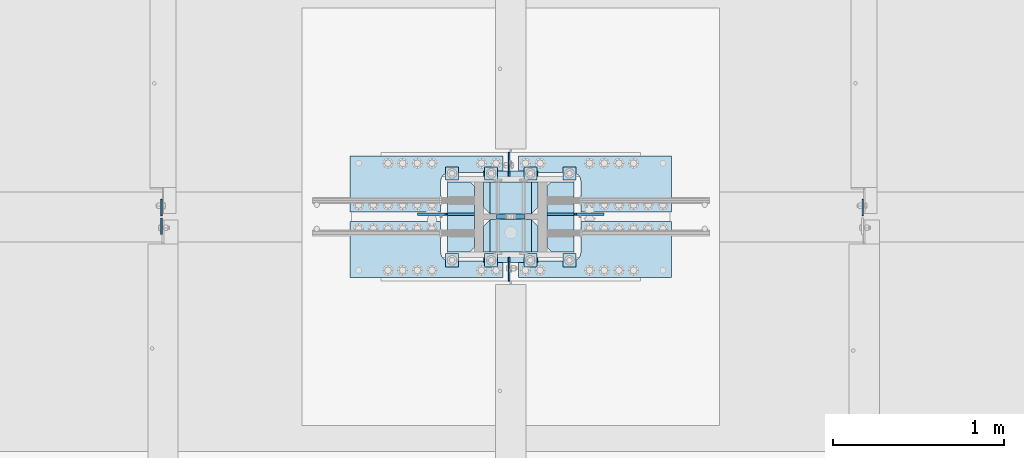
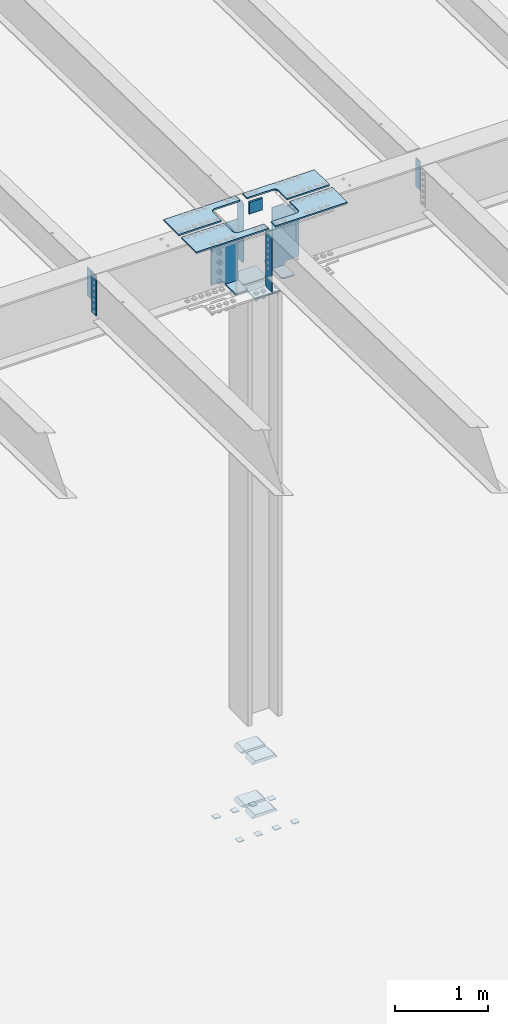
# One storey, part 1490 of 1763: 28 plates, 8 elements without a shape of their own.
"""IFC2X3 building model written with IfcOpenShell, lengths in millimetres."""

from ifc_helpers import new_model, si_unit, frame, origin_with_axes, place, context, subcontext, project, spatial, faceted_brep, material, type_object, element, aggregate, save


model = new_model("IFC2X3")

# Units and contexts
model_context = context("Model", 3, precision=1e-05, world=origin_with_axes())
body_context = subcontext(model_context, "Body", "Model", "MODEL_VIEW")
ifc_project = project(units=[si_unit("LENGTHUNIT", "METRE", prefix="MILLI"), si_unit("AREAUNIT", "SQUARE_METRE"), si_unit("VOLUMEUNIT", "CUBIC_METRE"), si_unit("MASSUNIT", "GRAM", prefix="KILO"), si_unit("TIMEUNIT", "SECOND"), si_unit("PLANEANGLEUNIT", "RADIAN"), si_unit("SOLIDANGLEUNIT", "STERADIAN"), si_unit("THERMODYNAMICTEMPERATUREUNIT", "DEGREE_CELSIUS"), si_unit("LUMINOUSINTENSITYUNIT", "LUMEN")], contexts=[model_context])

# Site, building, storey
site_placement = place(None, origin_with_axes())
site = spatial("IfcSite", under=ifc_project, at=site_placement, CompositionType="ELEMENT")
building_placement = place(site_placement, origin_with_axes())
building = spatial("IfcBuilding", under=site, at=building_placement, Name="Undefined", CompositionType="ELEMENT")
storey_placement = place(building_placement, origin_with_axes())
storey = spatial("IfcBuildingStorey", under=building, at=storey_placement, Name="Undefined", CompositionType="ELEMENT", Elevation=0.0)

# Assembly, plates
assembly_1_placement = place(storey_placement, origin_with_axes())
assembly_1 = element("IfcElementAssembly", 1, at=assembly_1_placement, inside=storey, Name="TEMPLATE", AssemblyPlace="NOTDEFINED", PredefinedType="RIGID_FRAME")
ifc_material_1 = material(Name="STEEL/A36")
plate_type_1 = type_object("IfcPlateType", PredefinedType="NOTDEFINED")
plate_1_placement = place(assembly_1_placement, frame((-49097.6372736986, 241.300000000003, 3916.3625), z_axis=(0.0, -1.0, 0.0), x_axis=(1.0, 0.0, 0.0)))
plate_1 = element("IfcPlate", 2, at=plate_1_placement, type_object=plate_type_1, material=ifc_material_1, Name="WASHER PLATE", context=body_context, shape_type="Brep", body=[
    faceted_brep([(0.0, -4.76249999999982, 0.0), (0.0, -4.76250000000073, 76.1999969482422), (0.0, 4.76250000000073, 76.1999969482422), (0.0, 4.76249999999982, 0.0), (76.1999969482422, -4.76249999999982, 76.1999969482422), (76.1999969482422, 4.76249999999982, 76.1999969482422), (76.1999969482931, -4.76249999991705, 0.0), (76.1999969482931, 4.76250000006257, 1.81898940354586e-12)], [[[0, 1, 2, 3]], [[1, 4, 5, 2]], [[4, 6, 7, 5]], [[6, 0, 3, 7]], [[5, 7, 3, 2]], [[6, 4, 1, 0]]]),
])
plate_2_placement = place(assembly_1_placement, frame((-49097.6372736986, 749.300000000003, 3916.3625), z_axis=(0.0, -1.0, 0.0), x_axis=(1.0, 0.0, 0.0)))
plate_2 = element("IfcPlate", 3, at=plate_2_placement, type_object=plate_type_1, material=ifc_material_1, Name="WASHER PLATE", context=body_context, shape_type="Brep", body=[
    faceted_brep([(0.0, -4.76249999999982, 0.0), (0.0, -4.76250000000073, 76.1999969482422), (0.0, 4.76250000000073, 76.1999969482422), (0.0, 4.76249999999982, 0.0), (76.1999969482422, -4.76249999999982, 76.1999969482422), (76.1999969482422, 4.76249999999982, 76.1999969482422), (76.1999969482931, -4.76249999991705, 0.0), (76.1999969482931, 4.76250000006257, 1.81898940354586e-12)], [[[0, 1, 2, 3]], [[1, 4, 5, 2]], [[4, 6, 7, 5]], [[6, 0, 3, 7]], [[5, 7, 3, 2]], [[6, 4, 1, 0]]]),
])
plate_3_placement = place(assembly_1_placement, frame((-49326.2372736986, 241.300000000003, 3916.3625), z_axis=(0.0, -1.0, 0.0), x_axis=(1.0, 0.0, 0.0)))
plate_3 = element("IfcPlate", 4, at=plate_3_placement, type_object=plate_type_1, material=ifc_material_1, Name="WASHER PLATE", context=body_context, shape_type="Brep", body=[
    faceted_brep([(0.0, -4.76249999999982, 0.0), (0.0, -4.76250000000073, 76.1999969482422), (0.0, 4.76250000000073, 76.1999969482422), (0.0, 4.76249999999982, 0.0), (76.1999969482422, -4.76249999999982, 76.1999969482422), (76.1999969482422, 4.76249999999982, 76.1999969482422), (76.1999969482931, -4.76249999991705, 0.0), (76.1999969482931, 4.76250000006257, 1.81898940354586e-12)], [[[0, 1, 2, 3]], [[1, 4, 5, 2]], [[4, 6, 7, 5]], [[6, 0, 3, 7]], [[5, 7, 3, 2]], [[6, 4, 1, 0]]]),
])
plate_4_placement = place(assembly_1_placement, frame((-49326.2372736986, 749.300000000003, 3916.3625), z_axis=(0.0, -1.0, 0.0), x_axis=(1.0, 0.0, 0.0)))
plate_4 = element("IfcPlate", 5, at=plate_4_placement, type_object=plate_type_1, material=ifc_material_1, Name="WASHER PLATE", context=body_context, shape_type="Brep", body=[
    faceted_brep([(0.0, -4.76249999999982, 0.0), (0.0, -4.76250000000073, 76.1999969482422), (0.0, 4.76250000000073, 76.1999969482422), (0.0, 4.76249999999982, 0.0), (76.1999969482422, -4.76249999999982, 76.1999969482422), (76.1999969482422, 4.76249999999982, 76.1999969482422), (76.1999969482931, -4.76249999991705, 0.0), (76.1999969482931, 4.76250000006257, 1.81898940354586e-12)], [[[0, 1, 2, 3]], [[1, 4, 5, 2]], [[4, 6, 7, 5]], [[6, 0, 3, 7]], [[5, 7, 3, 2]], [[6, 4, 1, 0]]]),
])
plate_5_placement = place(assembly_1_placement, frame((-49554.8372736986, 241.300000000003, 3916.3625), z_axis=(0.0, -1.0, 0.0), x_axis=(1.0, 0.0, 0.0)))
plate_5 = element("IfcPlate", 6, at=plate_5_placement, type_object=plate_type_1, material=ifc_material_1, Name="WASHER PLATE", context=body_context, shape_type="Brep", body=[
    faceted_brep([(0.0, -4.76249999999982, 0.0), (0.0, -4.76250000000073, 76.1999969482422), (0.0, 4.76250000000073, 76.1999969482422), (0.0, 4.76249999999982, 0.0), (76.1999969482422, -4.76249999999982, 76.1999969482422), (76.1999969482422, 4.76249999999982, 76.1999969482422), (76.1999969482931, -4.76249999991705, 0.0), (76.1999969482931, 4.76250000006257, 1.81898940354586e-12)], [[[0, 1, 2, 3]], [[1, 4, 5, 2]], [[4, 6, 7, 5]], [[6, 0, 3, 7]], [[5, 7, 3, 2]], [[6, 4, 1, 0]]]),
])
plate_6_placement = place(assembly_1_placement, frame((-49554.8372736986, 749.300000000003, 3916.3625), z_axis=(0.0, -1.0, 0.0), x_axis=(1.0, 0.0, 0.0)))
plate_6 = element("IfcPlate", 7, at=plate_6_placement, type_object=plate_type_1, material=ifc_material_1, Name="WASHER PLATE", context=body_context, shape_type="Brep", body=[
    faceted_brep([(0.0, -4.76249999999982, 0.0), (0.0, -4.76250000000073, 76.1999969482422), (0.0, 4.76250000000073, 76.1999969482422), (0.0, 4.76249999999982, 0.0), (76.1999969482422, -4.76249999999982, 76.1999969482422), (76.1999969482422, 4.76249999999982, 76.1999969482422), (76.1999969482931, -4.76249999991705, 0.0), (76.1999969482931, 4.76250000006257, 1.81898940354586e-12)], [[[0, 1, 2, 3]], [[1, 4, 5, 2]], [[4, 6, 7, 5]], [[6, 0, 3, 7]], [[5, 7, 3, 2]], [[6, 4, 1, 0]]]),
])
plate_7_placement = place(assembly_1_placement, frame((-49783.4372736986, 241.300000000003, 3916.3625), z_axis=(0.0, -1.0, 0.0), x_axis=(1.0, 0.0, 0.0)))
plate_7 = element("IfcPlate", 8, at=plate_7_placement, type_object=plate_type_1, material=ifc_material_1, Name="WASHER PLATE", context=body_context, shape_type="Brep", body=[
    faceted_brep([(0.0, -4.76249999999982, 0.0), (0.0, -4.76250000000073, 76.1999969482422), (0.0, 4.76250000000073, 76.1999969482422), (0.0, 4.76249999999982, 0.0), (76.1999969482422, -4.76249999999982, 76.1999969482422), (76.1999969482422, 4.76249999999982, 76.1999969482422), (76.1999969482931, -4.76249999991705, 0.0), (76.1999969482931, 4.76250000006257, 1.81898940354586e-12)], [[[0, 1, 2, 3]], [[1, 4, 5, 2]], [[4, 6, 7, 5]], [[6, 0, 3, 7]], [[5, 7, 3, 2]], [[6, 4, 1, 0]]]),
])
plate_8_placement = place(assembly_1_placement, frame((-49783.4372736986, 749.300000000003, 3916.3625), z_axis=(0.0, -1.0, 0.0), x_axis=(1.0, 0.0, 0.0)))
plate_8 = element("IfcPlate", 9, at=plate_8_placement, type_object=plate_type_1, material=ifc_material_1, Name="WASHER PLATE", context=body_context, shape_type="Brep", body=[
    faceted_brep([(0.0, -4.76249999999982, 0.0), (0.0, -4.76250000000073, 76.1999969482422), (0.0, 4.76250000000073, 76.1999969482422), (0.0, 4.76249999999982, 0.0), (76.1999969482422, -4.76249999999982, 76.1999969482422), (76.1999969482422, 4.76249999999982, 76.1999969482422), (76.1999969482931, -4.76249999991705, 0.0), (76.1999969482931, 4.76250000006257, 1.81898940354586e-12)], [[[0, 1, 2, 3]], [[1, 4, 5, 2]], [[4, 6, 7, 5]], [[6, 0, 3, 7]], [[5, 7, 3, 2]], [[6, 4, 1, 0]]]),
])
aggregate(assembly_1, [plate_1, plate_2, plate_3, plate_4, plate_5, plate_6, plate_7, plate_8])

assembly_2_placement = place(storey_placement, origin_with_axes())
assembly_2 = element("IfcElementAssembly", 10, at=assembly_2_placement, inside=storey, Name="COLUMN", AssemblyPlace="NOTDEFINED", PredefinedType="RIGID_FRAME")
plate_type_2 = type_object("IfcPlateType", PredefinedType="NOTDEFINED")
plate_9_placement = place(assembly_2_placement, frame((-49243.6872736986, 252.412500000003, 4826.0), z_axis=(-1.0, 0.0, 0.0), x_axis=(0.0, 1.0, 0.0)))
plate_9 = element("IfcPlate", 11, at=plate_9_placement, type_object=plate_type_2, material=ifc_material_1, Name="PLATE", context=body_context, shape_type="Brep", body=[
    faceted_brep([(188.118743896484, -19.0500000000002, 279.400001525879), (150.018745422363, 19.0500000000002, 317.5), (-1.13686837721616e-13, 19.0500000000002, 317.5), (-1.13686837721616e-13, -19.0500000000002, 279.400000002177), (188.118743896484, -19.0500000000002, 38.0999984741211), (0.0, -19.0500000000002, 38.099999997823), (0.0, 19.0500000000029, 0.0), (150.018745422363, 19.0500000000002, 0.0), (188.118743896484, 19.0500000000002, 38.0999984741211), (188.118743896484, 19.0500000000002, 279.400001525879)], [[[0, 1, 2, 3]], [[4, 5, 6, 7]], [[8, 4, 7]], [[0, 4, 8, 9]], [[5, 4, 0, 3]], [[6, 5, 3, 2]], [[9, 8, 7, 6, 2, 1]], [[9, 1, 0]]]),
])
plate_10_placement = place(assembly_2_placement, frame((-49243.6872736986, 473.868750000003, 4826.0), z_axis=(-1.0, 0.0, 0.0), x_axis=(0.0, 1.0, 0.0)))
plate_10 = element("IfcPlate", 12, at=plate_10_placement, type_object=plate_type_2, material=ifc_material_1, Name="PLATE", context=body_context, shape_type="Brep", body=[
    faceted_brep([(188.118743896484, -19.0500000000002, 38.0999984741211), (0.0, -19.0500000000002, 38.099999997823), (38.0999984741211, 19.0500000000002, 0.0), (188.118743896484, 19.0500000000002, 0.0), (0.0, 19.0500000000002, 38.0999984741211), (0.0, 19.0500000000002, 279.400001525879), (-1.13686837721616e-13, -19.0500000000002, 279.400000002177), (38.0999984741211, 19.0500000000002, 317.5), (188.118743896484, 19.0500000000002, 317.5), (188.118743896484, -19.0500000000002, 279.400001525879)], [[[0, 1, 2, 3]], [[4, 2, 1]], [[5, 6, 7]], [[8, 7, 6, 9]], [[8, 9, 0, 3]], [[4, 5, 7, 8, 3, 2]], [[1, 6, 5, 4]], [[1, 0, 9, 6]]]),
])
plate_11_placement = place(assembly_2_placement, frame((-49243.6872736986, 252.412500000003, 4114.8), z_axis=(-1.0, 0.0, 0.0), x_axis=(0.0, 1.0, 0.0)))
plate_11 = element("IfcPlate", 13, at=plate_11_placement, type_object=plate_type_2, material=ifc_material_1, Name="PLATE", context=body_context, shape_type="Brep", body=[
    faceted_brep([(188.118743896484, -19.0500000000002, 279.400001525879), (150.018745422363, 19.0500000000002, 317.5), (-1.13686837721616e-13, 19.0500000000002, 317.5), (-1.13686837721616e-13, -19.0500000000002, 279.400000002177), (188.118743896484, -19.0500000000002, 38.0999984741211), (0.0, -19.0500000000002, 38.099999997823), (0.0, 19.0500000000029, 0.0), (150.018745422363, 19.0500000000002, 0.0), (188.118743896484, 19.0500000000002, 38.0999984741211), (188.118743896484, 19.0500000000002, 279.400001525879)], [[[0, 1, 2, 3]], [[4, 5, 6, 7]], [[8, 4, 7]], [[0, 4, 8, 9]], [[5, 4, 0, 3]], [[6, 5, 3, 2]], [[9, 8, 7, 6, 2, 1]], [[9, 1, 0]]]),
])
plate_12_placement = place(assembly_2_placement, frame((-49243.6872736986, 473.868750000003, 4114.8), z_axis=(-1.0, 0.0, 0.0), x_axis=(0.0, 1.0, 0.0)))
plate_12 = element("IfcPlate", 14, at=plate_12_placement, type_object=plate_type_2, material=ifc_material_1, Name="PLATE", context=body_context, shape_type="Brep", body=[
    faceted_brep([(188.118743896484, -19.0500000000002, 38.0999984741211), (0.0, -19.0500000000002, 38.099999997823), (38.0999984741211, 19.0500000000002, 0.0), (188.118743896484, 19.0500000000002, 0.0), (0.0, 19.0500000000002, 38.0999984741211), (0.0, 19.0500000000002, 279.400001525879), (-1.13686837721616e-13, -19.0500000000002, 279.400000002177), (38.0999984741211, 19.0500000000002, 317.5), (188.118743896484, 19.0500000000002, 317.5), (188.118743896484, -19.0500000000002, 279.400001525879)], [[[0, 1, 2, 3]], [[4, 2, 1]], [[5, 6, 7]], [[8, 7, 6, 9]], [[8, 9, 0, 3]], [[4, 5, 7, 8, 3, 2]], [[1, 6, 5, 4]], [[1, 0, 9, 6]]]),
])
ifc_material_2 = material(Name="STEEL/A572-50")
plate_type_3 = type_object("IfcPlateType", PredefinedType="NOTDEFINED")
plate_13_placement = place(assembly_2_placement, frame((-49319.8872721725, 457.200000000004, 12073.4961653918), z_axis=(0.0, 0.0, -1.0), x_axis=(-1.0, 0.0, 0.0)))
plate_13 = element("IfcPlate", 15, at=plate_13_placement, type_object=plate_type_3, material=ifc_material_2, Name="PLATE", context=body_context, shape_type="Brep", body=[
    faceted_brep([(0.0, 12.7, 152.399990844726), (-1.45519152283669e-11, 7.27595761418343e-12, 165.099990844727), (165.099990844727, 0.0, 165.099990844727), (165.099990844727, 12.7, 152.399990844726), (0.0, -12.7, 152.399990844726), (165.099990844727, -12.7, 152.399990844726), (0.0, 12.6999999999971, -1.81898940354586e-12), (0.0, -12.6999999999971, -1.81898940354586e-12), (165.099990844727, -12.7, 0.0), (165.099990844727, 12.7, 0.0)], [[[0, 1, 2, 3]], [[1, 4, 5, 2]], [[6, 7, 4, 1, 0]], [[5, 8, 9, 3, 2]], [[8, 7, 6, 9]], [[9, 6, 0, 3]], [[7, 8, 5, 4]]]),
])

assembly_3_placement = place(storey_placement, origin_with_axes())
assembly_3 = element("IfcElementAssembly", 16, at=assembly_3_placement, inside=storey, Name="BEAM", AssemblyPlace="NOTDEFINED", PredefinedType="RIGID_FRAME")
plate_type_4 = type_object("IfcPlateType", PredefinedType="NOTDEFINED")
plate_14_placement = place(assembly_3_placement, frame((-51443.9622736983, 450.056250000003, 11850.9816334528), z_axis=(0.0, -1.0, 0.0), x_axis=(0.0, 0.0, -1.0)))
plate_14 = element("IfcPlate", 17, at=plate_14_placement, type_object=plate_type_4, material=ifc_material_1, Name="PLATE", context=body_context, shape_type="Brep", body=[
    faceted_brep([(0.0, -4.76249999999982, 0.0), (0.0, -4.76249999999709, 95.25), (0.0, 4.76249999999709, 95.25), (0.0, 4.76249999999982, 0.0), (533.400024414062, -4.76249999999709, 95.25), (533.400024414062, 4.76249999999709, 95.25), (533.400024414062, -4.76250000000073, 0.0), (533.400024414062, 4.76250000000073, 0.0)], [[[0, 1, 2, 3]], [[1, 4, 5, 2]], [[4, 6, 7, 5]], [[6, 0, 3, 7]], [[5, 7, 3, 2]], [[6, 4, 1, 0]]]),
])
plate_type_5 = type_object("IfcPlateType", PredefinedType="NOTDEFINED")
plate_15_placement = place(assembly_3_placement, frame((-51442.3750236983, 464.343750000002, 11851.4690855868), z_axis=(0.0, 1.0, 0.0), x_axis=(0.0, 0.0, -1.0)))
plate_15 = element("IfcPlate", 18, at=plate_15_placement, type_object=plate_type_5, material=ifc_material_1, Name="PLATE", context=body_context, shape_type="Brep", body=[
    faceted_brep([(0.0, -3.96900000000096, 0.0), (0.0, -3.96900000000096, 95.25), (0.0, 3.96900000000096, 95.25), (0.0, 3.96900000000096, 0.0), (381.0, -3.96899999999732, 95.25), (381.0, 3.96899999999732, 95.25), (381.0, -3.96900000001915, 3.34694050252438e-10), (381.0, 3.9690000000046, 3.20142135024071e-10)], [[[0, 1, 2, 3]], [[1, 4, 5, 2]], [[4, 6, 7, 5]], [[6, 0, 3, 7]], [[5, 7, 3, 2]], [[6, 4, 1, 0]]]),
])
aggregate(assembly_3, [plate_15, plate_14])

# Assembly, plate
assembly_4_placement = place(storey_placement, origin_with_axes())
assembly_4 = element("IfcElementAssembly", 19, at=assembly_4_placement, inside=storey, Name="BEAM", AssemblyPlace="NOTDEFINED", PredefinedType="RIGID_FRAME")
plate_16_placement = place(assembly_4_placement, frame((-47345.7178808412, 464.343750000002, 11851.4690855874), z_axis=(0.0, 1.0, 0.0), x_axis=(0.0, 0.0, -1.0)))
plate_16 = element("IfcPlate", 20, at=plate_16_placement, type_object=plate_type_5, material=ifc_material_1, Name="PLATE", context=body_context, shape_type="Brep", body=[
    faceted_brep([(0.0, -3.96900000000096, 0.0), (0.0, -3.96900000000096, 95.25), (0.0, 3.96900000000096, 95.25), (0.0, 3.96900000000096, 0.0), (381.0, -3.96899999999732, 95.25), (381.0, 3.96899999999732, 95.25), (381.0, -3.96900000001915, 3.34694050252438e-10), (381.0, 3.9690000000046, 3.20142135024071e-10)], [[[0, 1, 2, 3]], [[1, 4, 5, 2]], [[4, 6, 7, 5]], [[6, 0, 3, 7]], [[5, 7, 3, 2]], [[6, 4, 1, 0]]]),
])
aggregate(assembly_4, [plate_16])

assembly_5_placement = place(storey_placement, origin_with_axes())
assembly_5 = element("IfcElementAssembly", 21, at=assembly_5_placement, inside=storey, Name="PLATE", AssemblyPlace="NOTDEFINED", PredefinedType="RIGID_FRAME")
plate_type_6 = type_object("IfcPlateType", PredefinedType="NOTDEFINED")
plate_17_placement = place(assembly_5_placement, frame((-49446.8822232193, 811.212475585962, 11917.9211718047), z_axis=(-1.0, 0.0, 0.0), x_axis=(0.0, -1.0, 0.0)))
plate_17 = element("IfcPlate", 22, at=plate_17_placement, type_object=plate_type_6, material=ifc_material_2, Name="PLATE", context=body_context, shape_type="Brep", body=[
    faceted_brep([(95.2499921933502, -9.52499999999964, 0.0), (95.2499921933502, 9.52499999999964, 0.0), (95.2499921933485, 9.52499999999964, 314.264886800811), (95.2499921933485, -9.52499999999964, 314.264886800811), (99.1169117065035, 9.52499999999964, 333.705204445199), (99.1169117065035, -9.52499999999964, 333.705204445199), (110.12896683078, 9.52499999999964, 350.185910090775), (110.12896683078, -9.52499999999964, 350.185910090775), (126.609672074858, 9.52499999999964, 361.197965815933), (126.609672074858, -9.52499999999964, 361.197965815933), (146.049989578264, 9.52499999999964, 365.064886037871), (146.049989578264, -9.52499999999964, 365.064886037871), (325.437537969715, -9.52499999999964, 365.064892578259), (325.437530517578, 9.52499999999964, 365.064892578259), (0.0, -9.52500000000146, 0.0), (-4.77484718430787e-12, -9.52499999999964, 895.379943847656), (-4.77484718430787e-12, 9.52499999999964, 895.379943847656), (0.0, 9.52500000000146, 0.0), (325.437530517578, -9.52499999999964, 895.379943847656), (325.437530517578, 9.52499999999964, 895.379943847656)], [[[0, 1, 2, 3]], [[3, 2, 4, 5]], [[5, 4, 6, 7]], [[7, 6, 8, 9]], [[9, 8, 10, 11]], [[12, 11, 10, 13]], [[14, 15, 16, 17]], [[15, 18, 19, 16]], [[19, 18, 12, 13]], [[8, 6, 4, 2, 1, 17, 16, 19, 13, 10]], [[14, 17, 1, 0]], [[18, 15, 14, 0, 3, 5, 7, 9, 11, 12]]]),
])
aggregate(assembly_5, [plate_17])

assembly_6_placement = place(storey_placement, origin_with_axes())
assembly_6 = element("IfcElementAssembly", 23, at=assembly_6_placement, inside=storey, Name="PLATE", AssemblyPlace="NOTDEFINED", PredefinedType="RIGID_FRAME")
plate_18_placement = place(assembly_6_placement, frame((-49357.9922661248, 103.187524414041, 11917.9211718039), z_axis=(1.0, 0.0, 0.0), x_axis=(0.0, 1.0, 0.0)))
plate_18 = element("IfcPlate", 24, at=plate_18_placement, type_object=plate_type_6, material=ifc_material_2, Name="PLATE", context=body_context, shape_type="Brep", body=[
    faceted_brep([(95.2499921933502, -9.52499999999964, 0.0), (95.2499921933502, 9.52499999999964, 0.0), (95.2499921933766, 9.52499999999964, 314.329999292531), (95.2499921933766, -9.52499999999964, 314.329999292531), (99.1169118837276, 9.52499999999964, 333.770317364717), (99.1169118837276, -9.52499999999964, 333.770317364717), (110.128967485639, 9.52499999999964, 350.251023237332), (110.128967485639, -9.52499999999964, 350.251023237332), (126.609673358253, 9.52499999999964, 361.263078839242), (126.609673358253, -9.52499999999964, 361.263078839242), (146.049991430434, 9.52499999999964, 365.129998529592), (146.049991430434, -9.52499999999964, 365.129998529592), (325.437522710954, -9.52499999999964, 365.129998529606), (325.437530517578, 9.52499999999964, 365.129998529606), (0.0, -9.52500000000146, 0.0), (-4.77484718430787e-12, -9.52499999999964, 895.380126953125), (-4.77484718430787e-12, 9.52499999999964, 895.380126953125), (0.0, 9.52500000000146, 0.0), (325.437530517578, -9.52499999999964, 895.380126953125), (325.437530517578, 9.52499999999964, 895.380126953125)], [[[0, 1, 2, 3]], [[3, 2, 4, 5]], [[5, 4, 6, 7]], [[7, 6, 8, 9]], [[9, 8, 10, 11]], [[12, 11, 10, 13]], [[14, 15, 16, 17]], [[15, 18, 19, 16]], [[19, 18, 12, 13]], [[8, 6, 4, 2, 1, 17, 16, 19, 13, 10]], [[14, 17, 1, 0]], [[18, 15, 14, 0, 3, 5, 7, 9, 11, 12]]]),
])
aggregate(assembly_6, [plate_18])

assembly_7_placement = place(storey_placement, origin_with_axes())
assembly_7 = element("IfcElementAssembly", 25, at=assembly_7_placement, inside=storey, Name="PLATE", AssemblyPlace="NOTDEFINED", PredefinedType="RIGID_FRAME")
plate_19_placement = place(assembly_7_placement, frame((-49446.8822232193, 103.187524414041, 11917.9211718043), z_axis=(-1.0, 0.0, 0.0), x_axis=(0.0, 1.0, 0.0)))
plate_19 = element("IfcPlate", 26, at=plate_19_placement, type_object=plate_type_6, material=ifc_material_2, Name="PLATE", context=body_context, shape_type="Brep", body=[
    faceted_brep([(95.2499921933502, -9.52499999999964, 0.0), (95.2499921933502, 9.52499999999964, 0.0), (95.2499921933485, 9.52499999999964, 314.264886800811), (95.2499921933485, -9.52499999999964, 314.264886800811), (99.1169117065035, 9.52499999999964, 333.705204445199), (99.1169117065035, -9.52499999999964, 333.705204445199), (110.12896683078, 9.52499999999964, 350.185910090775), (110.12896683078, -9.52499999999964, 350.185910090775), (126.609672074858, 9.52499999999964, 361.197965815933), (126.609672074858, -9.52499999999964, 361.197965815933), (146.049989578264, 9.52499999999964, 365.064886037871), (146.049989578264, -9.52499999999964, 365.064886037871), (325.437537969715, -9.52499999999964, 365.064892578259), (325.437530517578, 9.52499999999964, 365.064892578259), (0.0, -9.52500000000146, 0.0), (-4.77484718430787e-12, -9.52499999999964, 895.379943847656), (-4.77484718430787e-12, 9.52499999999964, 895.379943847656), (0.0, 9.52500000000146, 0.0), (325.437530517578, -9.52499999999964, 895.379943847656), (325.437530517578, 9.52499999999964, 895.379943847656)], [[[0, 1, 2, 3]], [[3, 2, 4, 5]], [[5, 4, 6, 7]], [[7, 6, 8, 9]], [[9, 8, 10, 11]], [[12, 11, 10, 13]], [[14, 15, 16, 17]], [[15, 18, 19, 16]], [[19, 18, 12, 13]], [[8, 6, 4, 2, 1, 17, 16, 19, 13, 10]], [[14, 17, 1, 0]], [[18, 15, 14, 0, 3, 5, 7, 9, 11, 12]]]),
])
aggregate(assembly_7, [plate_19])

assembly_8_placement = place(storey_placement, origin_with_axes())
assembly_8 = element("IfcElementAssembly", 27, at=assembly_8_placement, inside=storey, Name="PLATE", AssemblyPlace="NOTDEFINED", PredefinedType="RIGID_FRAME")
plate_20_placement = place(assembly_8_placement, frame((-49357.9922661248, 811.212475585962, 11917.9211718043), z_axis=(1.0, 0.0, 0.0), x_axis=(0.0, -1.0, 0.0)))
plate_20 = element("IfcPlate", 28, at=plate_20_placement, type_object=plate_type_6, material=ifc_material_2, Name="PLATE", context=body_context, shape_type="Brep", body=[
    faceted_brep([(95.2499921933502, -9.52499999999964, 0.0), (95.2499921933502, 9.52499999999964, 0.0), (95.2499921933766, 9.52499999999964, 314.329999292531), (95.2499921933766, -9.52499999999964, 314.329999292531), (99.1169118837276, 9.52499999999964, 333.770317364717), (99.1169118837276, -9.52499999999964, 333.770317364717), (110.128967485639, 9.52499999999964, 350.251023237332), (110.128967485639, -9.52499999999964, 350.251023237332), (126.609673358253, 9.52499999999964, 361.263078839242), (126.609673358253, -9.52499999999964, 361.263078839242), (146.049991430434, 9.52499999999964, 365.129998529592), (146.049991430434, -9.52499999999964, 365.129998529592), (325.437522710954, -9.52499999999964, 365.129998529606), (325.437530517578, 9.52499999999964, 365.129998529606), (0.0, -9.52500000000146, 0.0), (-4.77484718430787e-12, -9.52499999999964, 895.380126953125), (-4.77484718430787e-12, 9.52499999999964, 895.380126953125), (0.0, 9.52500000000146, 0.0), (325.437530517578, -9.52499999999964, 895.380126953125), (325.437530517578, 9.52499999999964, 895.380126953125)], [[[0, 1, 2, 3]], [[3, 2, 4, 5]], [[5, 4, 6, 7]], [[7, 6, 8, 9]], [[9, 8, 10, 11]], [[12, 11, 10, 13]], [[14, 15, 16, 17]], [[15, 18, 19, 16]], [[19, 18, 12, 13]], [[8, 6, 4, 2, 1, 17, 16, 19, 13, 10]], [[14, 17, 1, 0]], [[18, 15, 14, 0, 3, 5, 7, 9, 11, 12]]]),
])
aggregate(assembly_8, [plate_20])

# Plate
plate_type_7 = type_object("IfcPlateType", PredefinedType="NOTDEFINED")
plate_21_placement = place(assembly_2_placement, frame((-49615.1622750886, 661.987506472304, 11076.5461713428), z_axis=(0.0, -1.0, 0.0), x_axis=(-1.0, 0.0, 0.0)))
plate_21 = element("IfcPlate", 29, at=plate_21_placement, type_object=plate_type_7, material=ifc_material_2, Name="PLATE", context=body_context, shape_type="Brep", body=[
    faceted_brep([(2.91038304567337e-11, -9.52499999999418, 25.4000000000015), (1.38243194669485e-10, -9.52500000000146, 384.175012588501), (1.67347025126219e-10, 9.52499999999782, 384.175012588501), (-5.82076609134674e-11, 9.52499999999418, 25.4000000000015), (25.3999996186831, -9.52499999999054, 409.575012207031), (25.3999996187049, 9.52500000001055, 409.575012207031), (155.574981689446, -9.52499999993961, 409.575012207031), (155.574981689468, 9.5250000000633, 409.575012207031), (155.574981689446, -9.52499999993961, -5.6843418860808e-13), (155.574981689468, 9.5250000000633, -5.6843418860808e-13), (25.399999618523, -9.52499999999054, -1.13686837721616e-13), (25.3999996185448, 9.52500000001055, -1.13686837721616e-13)], [[[0, 1, 2, 3]], [[1, 4, 5, 2]], [[4, 6, 7, 5]], [[6, 8, 9, 7]], [[8, 10, 11, 9]], [[10, 0, 3, 11]], [[5, 7, 9, 11, 3, 2]], [[10, 8, 6, 4, 1, 0]]]),
])

plate_22_placement = place(assembly_2_placement, frame((-49189.7123036761, 252.412499999581, 11076.5461711299), z_axis=(0.0, 1.0, 0.0), x_axis=(1.0, 0.0, 0.0)))
plate_22 = element("IfcPlate", 30, at=plate_22_placement, type_object=plate_type_7, material=ifc_material_2, Name="PLATE", context=body_context, shape_type="Brep", body=[
    faceted_brep([(2.91038304567337e-11, -9.52499999999418, 25.4000000000015), (1.38243194669485e-10, -9.52500000000146, 384.175012588501), (1.67347025126219e-10, 9.52499999999782, 384.175012588501), (-5.82076609134674e-11, 9.52499999999418, 25.4000000000015), (25.3999996186831, -9.52499999999054, 409.575012207031), (25.3999996187049, 9.52500000001055, 409.575012207031), (155.574981689446, -9.52499999993961, 409.575012207031), (155.574981689468, 9.5250000000633, 409.575012207031), (155.574981689446, -9.52499999993961, -5.6843418860808e-13), (155.574981689468, 9.5250000000633, -5.6843418860808e-13), (25.399999618523, -9.52499999999054, -1.13686837721616e-13), (25.3999996185448, 9.52500000001055, -1.13686837721616e-13)], [[[0, 1, 2, 3]], [[1, 4, 5, 2]], [[4, 6, 7, 5]], [[6, 8, 9, 7]], [[8, 10, 11, 9]], [[10, 0, 3, 11]], [[5, 7, 9, 11, 3, 2]], [[10, 8, 6, 4, 1, 0]]]),
])

plate_type_8 = type_object("IfcPlateType", PredefinedType="NOTDEFINED")
plate_23_placement = place(assembly_2_placement, frame((-49411.9617737836, 693.737499988477, 11887.8139109634), z_axis=(0.0, 1.0, 0.0), x_axis=(0.0, 0.0, -1.0)))
plate_23 = element("IfcPlate", 31, at=plate_23_placement, type_object=plate_type_8, material=ifc_material_1, Name="PLATE", context=body_context, shape_type="Brep", body=[
    faceted_brep([(0.0, -4.76250000000073, 25.3999996185303), (-1.4915713109076e-10, -4.76249999999709, 139.699996948242), (-1.4915713109076e-10, 4.76249999999709, 139.699996948242), (0.0, 4.76250000000073, 25.3999996185303), (800.099975585863, -4.76249999999709, 139.69999694821), (800.099975585863, 4.76249999999709, 139.69999694821), (800.099975585923, -4.76249999999709, 25.3999996180664), (800.099975585923, 4.76249999999709, 25.3999996180664), (774.699975967405, -4.76249999999709, -4.49063009000383e-10), (774.699975967405, 4.76249999999709, -4.49063009000383e-10), (25.3999996185303, -4.76250000000073, 0.0), (25.3999996185303, 4.76250000000073, 0.0)], [[[0, 1, 2, 3]], [[1, 4, 5, 2]], [[4, 6, 7, 5]], [[6, 8, 9, 7]], [[8, 10, 11, 9]], [[10, 0, 3, 11]], [[5, 7, 9, 11, 3, 2]], [[10, 8, 6, 4, 1, 0]]]),
])

plate_24_placement = place(assembly_2_placement, frame((-49411.9617737816, 220.662499987457, 11887.6590330839), z_axis=(0.0, -1.0, 0.0), x_axis=(0.0, 0.0, -1.0)))
plate_24 = element("IfcPlate", 32, at=plate_24_placement, type_object=plate_type_8, material=ifc_material_1, Name="PLATE", context=body_context, shape_type="Brep", body=[
    faceted_brep([(0.0, -4.76250000000073, 25.3999996185303), (-1.4915713109076e-10, -4.76249999999709, 139.699996948242), (-1.4915713109076e-10, 4.76249999999709, 139.699996948242), (0.0, 4.76250000000073, 25.3999996185303), (800.099975585863, -4.76249999999709, 139.69999694821), (800.099975585863, 4.76249999999709, 139.69999694821), (800.099975585923, -4.76249999999709, 25.3999996180664), (800.099975585923, 4.76249999999709, 25.3999996180664), (774.699975967405, -4.76249999999709, -4.49063009000383e-10), (774.699975967405, 4.76249999999709, -4.49063009000383e-10), (25.3999996185303, -4.76250000000073, 0.0), (25.3999996185303, 4.76250000000073, 0.0)], [[[0, 1, 2, 3]], [[1, 4, 5, 2]], [[4, 6, 7, 5]], [[6, 8, 9, 7]], [[8, 10, 11, 9]], [[10, 0, 3, 11]], [[5, 7, 9, 11, 3, 2]], [[10, 8, 6, 4, 1, 0]]]),
])

plate_type_9 = type_object("IfcPlateType", PredefinedType="NOTDEFINED")
plate_25_placement = place(assembly_2_placement, frame((-49243.6872736986, 188.912500000003, 10982.8837085135), z_axis=(-1.0, 0.0, 0.0), x_axis=(0.0, 1.0, 0.0)))
plate_25 = element("IfcPlate", 33, at=plate_25_placement, type_object=plate_type_9, material=ifc_material_2, Name="PLATE", context=body_context, shape_type="Brep", body=[
    faceted_brep([(-7.27595761418343e-12, -7.9375, 0.0), (0.0, -7.9375, 317.5), (0.0, 7.9375, 317.5), (-7.27595761418343e-12, 7.9375, 0.0), (213.518745422363, -7.9375, 317.5), (213.518745422363, 7.9375, 317.5), (251.618743896484, -7.9375, 279.400001525879), (251.618743896484, 7.9375, 279.400001525879), (251.618743896484, -7.9375, 38.0999984741211), (251.618743896484, 7.9375, 38.0999984741211), (213.518745422363, -7.9375, 0.0), (213.518745422363, 7.9375, 0.0)], [[[0, 1, 2, 3]], [[1, 4, 5, 2]], [[4, 6, 7, 5]], [[6, 8, 9, 7]], [[8, 10, 11, 9]], [[10, 0, 3, 11]], [[5, 7, 9, 11, 3, 2]], [[10, 8, 6, 4, 1, 0]]]),
])

plate_26_placement = place(assembly_2_placement, frame((-49243.6872736986, 473.868750000003, 10982.8837085135), z_axis=(-1.0, 0.0, 0.0), x_axis=(0.0, 1.0, 0.0)))
plate_26 = element("IfcPlate", 34, at=plate_26_placement, type_object=plate_type_9, material=ifc_material_2, Name="PLATE", context=body_context, shape_type="Brep", body=[
    faceted_brep([(0.0, -7.9375, 38.0999984741211), (0.0, -7.9375, 279.400001525879), (0.0, 7.9375, 279.400001525879), (0.0, 7.9375, 38.0999984741211), (38.0999984741211, -7.9375, 317.5), (38.0999984741211, 7.9375, 317.5), (251.618743896484, -7.9375, 317.5), (251.618743896484, 7.9375, 317.5), (251.618743896484, -7.9375, 0.0), (251.618743896484, 7.9375, 0.0), (38.0999984741211, -7.9375, 0.0), (38.0999984741211, 7.9375, 0.0)], [[[0, 1, 2, 3]], [[1, 4, 5, 2]], [[4, 6, 7, 5]], [[6, 8, 9, 7]], [[8, 10, 11, 9]], [[10, 0, 3, 11]], [[5, 7, 9, 11, 3, 2]], [[10, 8, 6, 4, 1, 0]]]),
])

plate_type_10 = type_object("IfcPlateType", PredefinedType="NOTDEFINED")
plate_27_placement = place(assembly_2_placement, frame((-49189.7122736986, 472.281250000003, 11889.3461714953), z_axis=(1.0, 0.0, 0.0), x_axis=(0.0, 0.0, -1.0)))
plate_27 = element("IfcPlate", 35, at=plate_27_placement, type_object=plate_type_10, material=ifc_material_2, Name="PLATE", context=body_context, shape_type="Brep", body=[
    faceted_brep([(17.4625027313377, -7.9375, 155.574972729497), (17.4625027313377, 7.9375, 155.574972729497), (0.0, 7.9375, 155.574972729497), (0.0, -7.9375, 155.574972729497), (27.1826617674287, -7.9375, 157.508432574672), (27.1826617674287, 7.9375, 157.508432574672), (35.423014703736, -7.9375, 163.014460375627), (35.423014703736, 7.9375, 163.014460375627), (40.9290425046929, -7.9375, 171.254813311934), (40.9290425046929, 7.9375, 171.254813311934), (42.862502349868, -7.9375, 180.974972348027), (42.862502349868, 7.9375, 180.974972348027), (42.862502349868, -7.9375, 333.374991040022), (42.862502349868, 7.9375, 333.375), (803.275024414062, -7.9375, 0.0), (-7.27595761418343e-12, -7.9375, 0.0), (-7.27595761418343e-12, 7.9375, 0.0), (803.275024414062, 7.9375, 0.0), (803.275024414062, 7.9375, 155.574937444078), (803.275024414062, -7.9375, 155.574937444078), (785.812508628436, 7.9375, 155.574937444078), (785.812508628436, -7.9375, 155.574937444078), (776.092348837135, 7.9375, 157.508397602076), (776.092348837135, -7.9375, 157.508397602076), (767.85199550001, 7.9375, 163.014426246235), (767.85199550001, -7.9375, 163.014426246235), (762.345967916626, 7.9375, 171.254780292154), (762.345967916626, -7.9375, 171.254780292154), (760.412509009908, 7.9375, 180.974940332351), (760.412509009908, -7.9375, 180.974940332351), (760.412528628351, -7.9375, 333.375), (760.412528628351, 7.9375, 333.375)], [[[0, 1, 2, 3]], [[4, 5, 1, 0]], [[6, 7, 5, 4]], [[8, 9, 7, 6]], [[10, 11, 9, 8]], [[12, 13, 11, 10]], [[14, 15, 16, 17]], [[14, 17, 18, 19]], [[19, 18, 20, 21]], [[21, 20, 22, 23]], [[23, 22, 24, 25]], [[25, 24, 26, 27]], [[27, 26, 28, 29]], [[30, 29, 28, 31]], [[8, 6, 4, 0, 3, 15, 14, 19, 21, 23, 25, 27, 29, 30, 12, 10]], [[16, 15, 3, 2]], [[31, 28, 26, 24, 22, 20, 18, 17, 16, 2, 1, 5, 7, 9, 11, 13]], [[30, 31, 13, 12]]]),
])

plate_28_placement = place(assembly_2_placement, frame((-49615.1622736986, 472.281250000003, 11889.3461714953), z_axis=(-1.0, 0.0, 0.0), x_axis=(0.0, 0.0, -1.0)))
plate_28 = element("IfcPlate", 36, at=plate_28_placement, type_object=plate_type_10, material=ifc_material_2, Name="PLATE", context=body_context, shape_type="Brep", body=[
    faceted_brep([(17.4625027313377, -7.9375, 155.574972729497), (17.4625027313377, 7.9375, 155.574972729497), (0.0, 7.9375, 155.574972729497), (0.0, -7.9375, 155.574972729497), (27.1826617674287, -7.9375, 157.508432574672), (27.1826617674287, 7.9375, 157.508432574672), (35.423014703736, -7.9375, 163.014460375627), (35.423014703736, 7.9375, 163.014460375627), (40.9290425046929, -7.9375, 171.254813311934), (40.9290425046929, 7.9375, 171.254813311934), (42.862502349868, -7.9375, 180.974972348027), (42.862502349868, 7.9375, 180.974972348027), (42.862502349868, -7.9375, 333.374991040022), (42.862502349868, 7.9375, 333.375), (803.275024414062, -7.9375, 0.0), (-7.27595761418343e-12, -7.9375, 0.0), (-7.27595761418343e-12, 7.9375, 0.0), (803.275024414062, 7.9375, 0.0), (803.275024414062, 7.9375, 155.574989183879), (803.275024414062, -7.9375, 155.574989183879), (785.812506702398, 7.9375, 155.574989183879), (785.812506702398, -7.9375, 155.574989183879), (776.092346911095, 7.9375, 157.508449341876), (776.092346911095, -7.9375, 157.508449341876), (767.851993573971, 7.9375, 163.014477986035), (767.851993573971, -7.9375, 163.014477986035), (762.345965990588, 7.9375, 171.254832031955), (762.345965990588, -7.9375, 171.254832031955), (760.412507083869, 7.9375, 180.974992072152), (760.412507083869, -7.9375, 180.974992072152), (760.412528628351, -7.9375, 333.375), (760.412528628351, 7.9375, 333.375)], [[[0, 1, 2, 3]], [[4, 5, 1, 0]], [[6, 7, 5, 4]], [[8, 9, 7, 6]], [[10, 11, 9, 8]], [[12, 13, 11, 10]], [[14, 15, 16, 17]], [[14, 17, 18, 19]], [[19, 18, 20, 21]], [[21, 20, 22, 23]], [[23, 22, 24, 25]], [[25, 24, 26, 27]], [[27, 26, 28, 29]], [[30, 29, 28, 31]], [[8, 6, 4, 0, 3, 15, 14, 19, 21, 23, 25, 27, 29, 30, 12, 10]], [[16, 15, 3, 2]], [[31, 28, 26, 24, 22, 20, 18, 17, 16, 2, 1, 5, 7, 9, 11, 13]], [[30, 31, 13, 12]]]),
])

aggregate(assembly_2, [plate_9, plate_10, plate_11, plate_12, plate_21, plate_22, plate_13, plate_25, plate_26, plate_27, plate_28, plate_23, plate_24])

save(model, "model.ifc")
